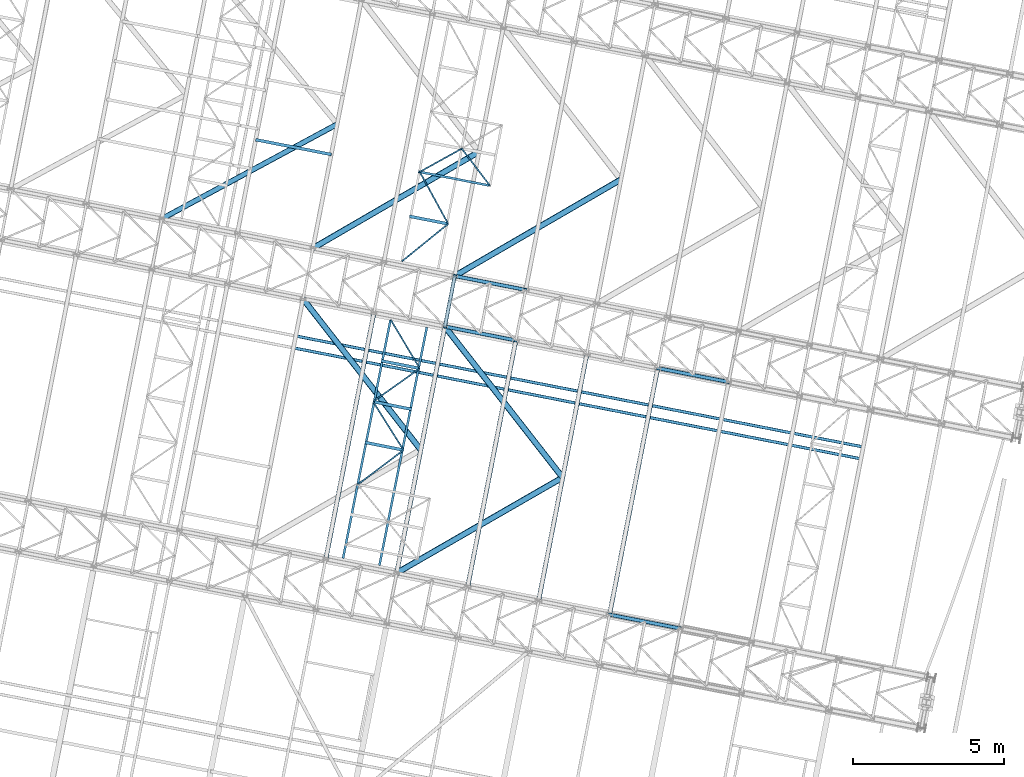
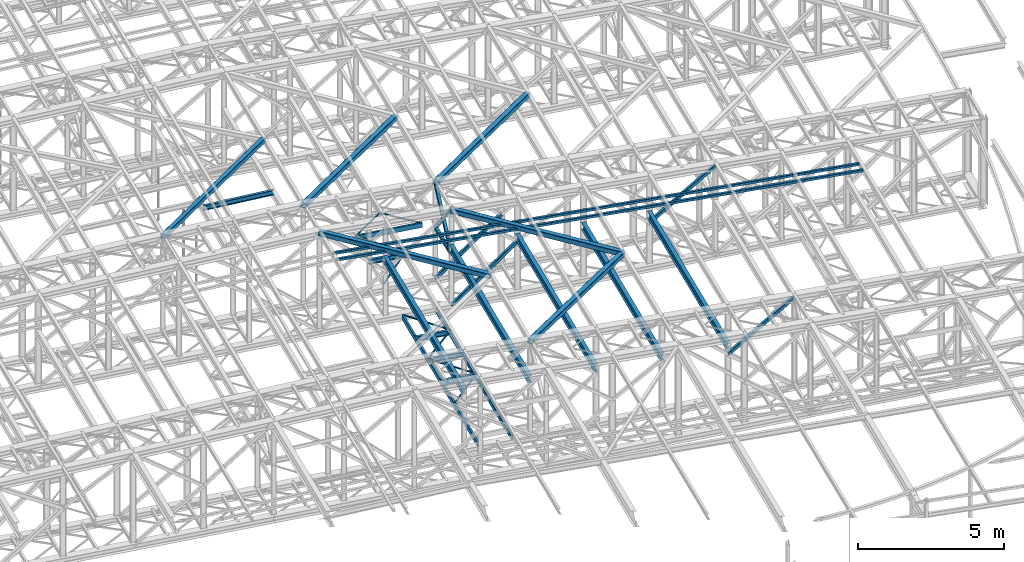
# One storey, part 60 of 215: 30 beams, 6 members, 36 elements without a shape of their own.
"""IFC2X3 building model written with IfcOpenShell, lengths in millimetres."""

from ifc_helpers import new_model, si_unit, frame, origin_with_axes, origin_2d_with_axis, place, context, subcontext, project, spatial, hollow_rectangle, i_section, u_section, extrude, material, type_object, element, aggregate, save


model = new_model("IFC2X3")

# Units and contexts
model_context = context("Model", 3, precision=1e-05, world=origin_with_axes())
body_context = subcontext(model_context, "Body", "Model", "MODEL_VIEW")
ifc_project = project(units=[si_unit("LENGTHUNIT", "METRE", prefix="MILLI"), si_unit("AREAUNIT", "SQUARE_METRE"), si_unit("VOLUMEUNIT", "CUBIC_METRE"), si_unit("MASSUNIT", "GRAM", prefix="KILO"), si_unit("TIMEUNIT", "SECOND"), si_unit("PLANEANGLEUNIT", "RADIAN"), si_unit("SOLIDANGLEUNIT", "STERADIAN"), si_unit("THERMODYNAMICTEMPERATUREUNIT", "DEGREE_CELSIUS"), si_unit("LUMINOUSINTENSITYUNIT", "LUMEN")], contexts=[model_context])

# Site, building, storey
site_placement = place(None, origin_with_axes())
site = spatial("IfcSite", under=ifc_project, at=site_placement, CompositionType="ELEMENT")
building_placement = place(site_placement, origin_with_axes())
building = spatial("IfcBuilding", under=site, at=building_placement, Name="Undefined", CompositionType="ELEMENT")
storey_placement = place(building_placement, origin_with_axes())
storey = spatial("IfcBuildingStorey", under=building, at=storey_placement, Name="Undefined", CompositionType="ELEMENT", Elevation=0.0)

# Assembly, beam
assembly_1_placement = place(storey_placement, origin_with_axes())
assembly_1 = element("IfcElementAssembly", 1, at=assembly_1_placement, inside=storey, Name="Steel Assembly", AssemblyPlace="NOTDEFINED", PredefinedType="RIGID_FRAME")
ifc_material = material(Name="STEEL/S275JR")
beam_type_1 = type_object("IfcBeamType", PredefinedType="NOTDEFINED")
beam_1_placement = place(assembly_1_placement, frame((73803.5514468927, 26333.0860836415, 10796.0000008389), z_axis=(0.981422364268518, -0.191859461052493, -0.000300197000082615), x_axis=(0.191859470081235, 0.981422408415534, 0.0)))
beam_1 = element("IfcBeam", 2, at=beam_1_placement, type_object=beam_type_1, material=ifc_material, context=body_context, shape_type="SweptSolid", body=[
    extrude(hollow_rectangle(XDim=120.0, YDim=120.0, WallThickness=5.0, InnerFilletRadius=5.0, OuterFilletRadius=10.0, at=origin_2d_with_axis()), frame((1699.99999941724, 1.81898940354586e-12, 0.0), z_axis=(-1.0, 0.0, 0.0), x_axis=(-6.93889390390723e-18, -1.0, -3.46944695195361e-18)), (0.0, 0.0, 1.0), 1700.0),
])
aggregate(assembly_1, [beam_1])

assembly_2_placement = place(storey_placement, origin_with_axes())
assembly_2 = element("IfcElementAssembly", 3, at=assembly_2_placement, inside=storey, Name="Steel Assembly", AssemblyPlace="NOTDEFINED", PredefinedType="RIGID_FRAME")
beam_type_2 = type_object("IfcBeamType", PredefinedType="NOTDEFINED")
beam_2_placement = place(assembly_2_placement, frame((68930.1374258507, 26009.7768922294, 12727.9809499878), z_axis=(-0.0304080339975108, 0.00594450399951394, -0.999519891918418), x_axis=(0.980943076639626, -0.191809005929534, -0.0309836349886174)))
beam_2 = element("IfcBeam", 4, at=beam_2_placement, type_object=beam_type_2, material=ifc_material, context=body_context, shape_type="SweptSolid", body=[
    extrude(hollow_rectangle(XDim=100.0, YDim=100.0, WallThickness=5.0, InnerFilletRadius=5.0, OuterFilletRadius=10.0, at=origin_2d_with_axis()), frame((19054.6230953848, 6.46745726067925e-12, -1.32218008037815e-13), z_axis=(-1.0, 0.0, 0.0), x_axis=(-6.93889390390723e-18, -1.0, -3.46944695195361e-18)), (0.0, 0.0, 1.0), 19054.6),
])
aggregate(assembly_2, [beam_2])

assembly_3_placement = place(storey_placement, origin_with_axes())
assembly_3 = element("IfcElementAssembly", 5, at=assembly_3_placement, inside=storey, Name="Steel Assembly", AssemblyPlace="NOTDEFINED", PredefinedType="RIGID_FRAME")
beam_3_placement = place(assembly_3_placement, frame((68853.376958442, 25617.2111899104, 12727.9809498765), z_axis=(-0.0304080339975108, 0.00594450399951394, -0.999519891918418), x_axis=(0.980943076639626, -0.191809005929534, -0.0309836349886174)))
beam_3 = element("IfcBeam", 6, at=beam_3_placement, type_object=beam_type_2, material=ifc_material, context=body_context, shape_type="SweptSolid", body=[
    extrude(hollow_rectangle(XDim=100.0, YDim=100.0, WallThickness=5.0, InnerFilletRadius=5.0, OuterFilletRadius=10.0, at=origin_2d_with_axis()), frame((19054.6230953848, 6.46745726067925e-12, -1.32218008037815e-13), z_axis=(-1.0, 0.0, 0.0), x_axis=(-6.93889390390723e-18, -1.0, -3.46944695195361e-18)), (0.0, 0.0, 1.0), 19054.6),
])
aggregate(assembly_3, [beam_3])

assembly_4_placement = place(storey_placement, origin_with_axes())
assembly_4 = element("IfcElementAssembly", 7, at=assembly_4_placement, inside=storey, Name="Steel Assembly", AssemblyPlace="NOTDEFINED", PredefinedType="RIGID_FRAME")
beam_type_3 = type_object("IfcBeamType", PredefinedType="NOTDEFINED")
beam_4_placement = place(assembly_4_placement, frame((73910.5829988377, 29724.9162021048, 8745.0), z_axis=(0.0, 0.0, -1.0), x_axis=(-0.776901735888944, -0.629621864909999, 0.0)))
beam_4 = element("IfcBeam", 8, at=beam_4_placement, type_object=beam_type_3, material=ifc_material, context=body_context, shape_type="SweptSolid", body=[
    extrude(hollow_rectangle(XDim=50.0, YDim=50.0, WallThickness=3.0, InnerFilletRadius=3.0, OuterFilletRadius=6.0, at=origin_2d_with_axis()), frame((1967.92286163102, 0.0, 0.0), z_axis=(-1.0, 0.0, 0.0), x_axis=(-6.93889390390723e-18, -1.0, -3.46944695195361e-18)), (0.0, 0.0, 1.0), 1967.9),
])
aggregate(assembly_4, [beam_4])

assembly_5_placement = place(storey_placement, origin_with_axes())
assembly_5 = element("IfcElementAssembly", 9, at=assembly_5_placement, inside=storey, Name="Steel Assembly", AssemblyPlace="NOTDEFINED", PredefinedType="RIGID_FRAME")
beam_5_placement = place(assembly_5_placement, frame((72972.494718833, 31442.4142075838, 8745.0), z_axis=(0.0, 0.0, -1.0), x_axis=(0.479352670880574, -0.877622365781354, 0.0)))
beam_5 = element("IfcBeam", 10, at=beam_5_placement, type_object=beam_type_3, material=ifc_material, context=body_context, shape_type="SweptSolid", body=[
    extrude(hollow_rectangle(XDim=50.0, YDim=50.0, WallThickness=3.0, InnerFilletRadius=3.0, OuterFilletRadius=6.0, at=origin_2d_with_axis()), frame((1956.98978542684, 0.0, 0.0), z_axis=(-1.0, 0.0, 0.0), x_axis=(-6.93889390390723e-18, -1.0, -3.46944695195361e-18)), (0.0, 0.0, 1.0), 1957.0),
])
aggregate(assembly_5, [beam_5])

assembly_6_placement = place(storey_placement, origin_with_axes())
assembly_6 = element("IfcElementAssembly", 11, at=assembly_6_placement, inside=storey, Name="Steel Assembly", AssemblyPlace="NOTDEFINED", PredefinedType="RIGID_FRAME")
beam_6_placement = place(assembly_6_placement, frame((72972.494718833, 31442.4142075838, 8745.0), z_axis=(0.0, 0.0, -1.0), x_axis=(0.874632709458512, 0.484786162699868, 0.0)))
beam_6 = element("IfcBeam", 12, at=beam_6_placement, type_object=beam_type_3, material=ifc_material, context=body_context, shape_type="SweptSolid", body=[
    extrude(hollow_rectangle(XDim=50.0, YDim=50.0, WallThickness=3.0, InnerFilletRadius=3.0, OuterFilletRadius=6.0, at=origin_2d_with_axis()), frame((1585.49676732963, -5.45696821063757e-12, -1.81898940354586e-12), z_axis=(-1.0, 0.0, 0.0), x_axis=(-6.93889390390723e-18, -1.0, -3.46944695195361e-18)), (0.0, 0.0, 1.0), 1585.5),
])
aggregate(assembly_6, [beam_6])

assembly_7_placement = place(storey_placement, origin_with_axes())
assembly_7 = element("IfcElementAssembly", 13, at=assembly_7_placement, inside=storey, Name="Steel Assembly", AssemblyPlace="NOTDEFINED", PredefinedType="RIGID_FRAME")
beam_7_placement = place(assembly_7_placement, frame((74359.2226940093, 32211.0444873669, 8745.0), z_axis=(0.0, 0.0, -1.0), x_axis=(0.606331787679529, -0.795211772579699, 0.0)))
beam_7 = element("IfcBeam", 14, at=beam_7_placement, type_object=beam_type_3, material=ifc_material, context=body_context, shape_type="SweptSolid", body=[
    extrude(hollow_rectangle(XDim=50.0, YDim=50.0, WallThickness=3.0, InnerFilletRadius=3.0, OuterFilletRadius=6.0, at=origin_2d_with_axis()), frame((1538.169383869, 0.0, 1.81898940354586e-12), z_axis=(-1.0, 0.0, 0.0), x_axis=(-6.93889390390723e-18, -1.0, -3.46944695195361e-18)), (0.0, 0.0, 1.0), 1538.2),
])
aggregate(assembly_7, [beam_7])

assembly_8_placement = place(storey_placement, origin_with_axes())
assembly_8 = element("IfcElementAssembly", 15, at=assembly_8_placement, inside=storey, Name="Steel Assembly", AssemblyPlace="NOTDEFINED", PredefinedType="RIGID_FRAME")
beam_8_placement = place(assembly_8_placement, frame((72436.2666917399, 22250.5172943073, 8745.0), z_axis=(0.0, 0.0, -1.0), x_axis=(-0.799182100298458, -0.601088987224475, 0.0)))
beam_8 = element("IfcBeam", 16, at=beam_8_placement, type_object=beam_type_3, material=ifc_material, context=body_context, shape_type="SweptSolid", body=[
    extrude(hollow_rectangle(XDim=50.0, YDim=50.0, WallThickness=3.0, InnerFilletRadius=3.0, OuterFilletRadius=6.0, at=origin_2d_with_axis()), frame((1894.42434231418, -2.10323352324758e-13, 0.0), z_axis=(-1.0, 0.0, 0.0), x_axis=(-6.93889390390723e-18, -1.0, -3.46944695195361e-18)), (0.0, 0.0, 1.0), 1894.4),
])
aggregate(assembly_8, [beam_8])

assembly_9_placement = place(storey_placement, origin_with_axes())
assembly_9 = element("IfcElementAssembly", 17, at=assembly_9_placement, inside=storey, Name="Steel Assembly", AssemblyPlace="NOTDEFINED", PredefinedType="RIGID_FRAME")
beam_9_placement = place(assembly_9_placement, frame((71429.7896565875, 23852.7578601774, 8745.0), z_axis=(0.0, 0.0, -1.0), x_axis=(0.531926949772059, -0.846790245637131, 0.0)))
beam_9 = element("IfcBeam", 18, at=beam_9_placement, type_object=beam_type_3, material=ifc_material, context=body_context, shape_type="SweptSolid", body=[
    extrude(hollow_rectangle(XDim=50.0, YDim=50.0, WallThickness=3.0, InnerFilletRadius=3.0, OuterFilletRadius=6.0, at=origin_2d_with_axis()), frame((1892.13394173326, 0.0, 0.0), z_axis=(-1.0, 0.0, 0.0), x_axis=(-6.93889390390723e-18, -1.0, -3.46944695195361e-18)), (0.0, 0.0, 1.0), 1892.1),
])
aggregate(assembly_9, [beam_9])

assembly_10_placement = place(storey_placement, origin_with_axes())
assembly_10 = element("IfcElementAssembly", 19, at=assembly_10_placement, inside=storey, Name="Steel Assembly", AssemblyPlace="NOTDEFINED", PredefinedType="RIGID_FRAME")
beam_10_placement = place(assembly_10_placement, frame((72973.2361306411, 24947.2721146437, 8745.0), z_axis=(0.0, 0.0, -1.0), x_axis=(-0.815715337122236, -0.57845353208668, 0.0)))
beam_10 = element("IfcBeam", 20, at=beam_10_placement, type_object=beam_type_3, material=ifc_material, context=body_context, shape_type="SweptSolid", body=[
    extrude(hollow_rectangle(XDim=50.0, YDim=50.0, WallThickness=3.0, InnerFilletRadius=3.0, OuterFilletRadius=6.0, at=origin_2d_with_axis()), frame((1892.13859743143, 0.0, 0.0), z_axis=(-1.0, 0.0, 0.0), x_axis=(-6.93889390390723e-18, -1.0, -3.46944695195361e-18)), (0.0, 0.0, 1.0), 1892.1),
])
aggregate(assembly_10, [beam_10])

assembly_11_placement = place(storey_placement, origin_with_axes())
assembly_11 = element("IfcElementAssembly", 21, at=assembly_11_placement, inside=storey, Name="Steel Assembly", AssemblyPlace="NOTDEFINED", PredefinedType="RIGID_FRAME")
beam_11_placement = place(assembly_11_placement, frame((72011.5958000029, 26561.0332888829, 8745.0), z_axis=(0.0, 0.0, -1.0), x_axis=(0.511903665923393, -0.859042860871442, 0.0)))
beam_11 = element("IfcBeam", 22, at=beam_11_placement, type_object=beam_type_3, material=ifc_material, context=body_context, shape_type="SweptSolid", body=[
    extrude(hollow_rectangle(XDim=50.0, YDim=50.0, WallThickness=3.0, InnerFilletRadius=3.0, OuterFilletRadius=6.0, at=origin_2d_with_axis()), frame((1878.55722617164, 1.44476343540883e-11, 0.0), z_axis=(-1.0, 0.0, 0.0), x_axis=(-6.93889390390723e-18, -1.0, -3.46944695195361e-18)), (0.0, 0.0, 1.0), 1878.6),
])
aggregate(assembly_11, [beam_11])

assembly_12_placement = place(storey_placement, origin_with_axes())
assembly_12 = element("IfcElementAssembly", 23, at=assembly_12_placement, inside=storey, Name="Steel Assembly", AssemblyPlace="NOTDEFINED", PredefinedType="RIGID_FRAME")
beam_type_4 = type_object("IfcBeamType", Name="UPN200", PredefinedType="NOTDEFINED")
beam_12_placement = place(assembly_12_placement, frame((72923.7516788256, 31451.4251382555, 8670.00000003361), z_axis=(0.0, 0.0, -1.0), x_axis=(0.981375096584427, -0.192101326918653, 0.0)))
beam_12 = element("IfcBeam", 24, at=beam_12_placement, type_object=beam_type_4, material=ifc_material, ObjectType="UPN200", context=body_context, shape_type="SweptSolid", body=[
    extrude(u_section(Depth=200.0, FlangeWidth=75.0, WebThickness=8.5, FlangeThickness=11.5, FilletRadius=11.5, EdgeRadius=6.0, FlangeSlope=0.0798299857122373, at=origin_2d_with_axis()), frame((2450.55492376749, 6.80165624868804e-14, 0.0), z_axis=(-1.0, 0.0, 0.0), x_axis=(-6.93889390390723e-18, -1.0, -3.46944695195361e-18)), (0.0, 0.0, 1.0), 2450.6),
])
aggregate(assembly_12, [beam_12])

assembly_13_placement = place(storey_placement, origin_with_axes())
assembly_13 = element("IfcElementAssembly", 25, at=assembly_13_placement, inside=storey, Name="Steel Assembly", AssemblyPlace="NOTDEFINED", PredefinedType="RIGID_FRAME")
beam_13_placement = place(assembly_13_placement, frame((72003.5163613566, 26542.1939828094, 8670.0000000337), z_axis=(0.0, 0.0, -1.0), x_axis=(-0.195275706966075, -0.980748386829619, 0.0)))
beam_13 = element("IfcBeam", 26, at=beam_13_placement, type_object=beam_type_4, material=ifc_material, ObjectType="UPN200", context=body_context, shape_type="SweptSolid", body=[
    extrude(u_section(Depth=200.0, FlangeWidth=75.0, WebThickness=8.5, FlangeThickness=11.5, FilletRadius=11.5, EdgeRadius=6.0, FlangeSlope=0.0798299857122373, at=origin_2d_with_axis()), frame((8020.04435865904, 2.22600947637459e-13, 0.0), z_axis=(-1.0, 0.0, 0.0), x_axis=(-6.93889390390723e-18, -1.0, -3.46944695195361e-18)), (0.0, 0.0, 1.0), 8020.0),
])
aggregate(assembly_13, [beam_13])

assembly_14_placement = place(storey_placement, origin_with_axes())
assembly_14 = element("IfcElementAssembly", 27, at=assembly_14_placement, inside=storey, Name="Steel Assembly", AssemblyPlace="NOTDEFINED", PredefinedType="RIGID_FRAME")
beam_14_placement = place(assembly_14_placement, frame((71639.6576296686, 18441.7832191884, 8670.00000000005), z_axis=(0.0, 0.0, -1.0), x_axis=(0.195280701088085, 0.980747392442389, 0.0)))
beam_14 = element("IfcBeam", 28, at=beam_14_placement, type_object=beam_type_4, material=ifc_material, ObjectType="UPN200", context=body_context, shape_type="SweptSolid", body=[
    extrude(u_section(Depth=200.0, FlangeWidth=75.0, WebThickness=8.5, FlangeThickness=11.5, FilletRadius=11.5, EdgeRadius=6.0, FlangeSlope=0.0798299857122373, at=origin_2d_with_axis()), frame((8020.04452082332, 0.0, 0.0), z_axis=(-1.0, 0.0, 0.0), x_axis=(-6.93889390390723e-18, -1.0, -3.46944695195361e-18)), (0.0, 0.0, 1.0), 8020.0),
])
aggregate(assembly_14, [beam_14])

# Assembly, member
assembly_15_placement = place(storey_placement, origin_with_axes())
assembly_15 = element("IfcElementAssembly", 29, at=assembly_15_placement, inside=storey, Name="Steel Assembly", AssemblyPlace="NOTDEFINED", PredefinedType="RIGID_FRAME")
member_type = type_object("IfcMemberType", PredefinedType="NOTDEFINED")
member_1_placement = place(assembly_15_placement, frame((74129.7125455571, 28001.5041774558, 10796.0000008371), z_axis=(0.981465144014204, -0.191640629002775, 0.000200999000003501), x_axis=(-0.128461058963395, -0.657119307812757, 0.742759699788354)))
member_1 = element("IfcMember", 30, at=member_1_placement, type_object=member_type, material=ifc_material, context=body_context, shape_type="SweptSolid", body=[
    extrude(hollow_rectangle(XDim=120.0, YDim=120.0, WallThickness=5.0, InnerFilletRadius=5.0, OuterFilletRadius=10.0, at=origin_2d_with_axis()), frame((2538.98807297308, -7.4168997650766e-12, -1.4616192556948e-11), z_axis=(-1.0, 0.0, 0.0), x_axis=(-6.93889390390723e-18, -1.0, -3.46944695195361e-18)), (0.0, 0.0, 1.0), 2539.0),
])
aggregate(assembly_15, [member_1])

assembly_16_placement = place(storey_placement, origin_with_axes())
assembly_16 = element("IfcElementAssembly", 31, at=assembly_16_placement, inside=storey, Name="Steel Assembly", AssemblyPlace="NOTDEFINED", PredefinedType="RIGID_FRAME")
member_2_placement = place(assembly_16_placement, frame((73803.5514468927, 26333.0860836415, 10796.0000008389), z_axis=(0.981465144014204, -0.191640629002775, -0.000200999000003501), x_axis=(0.128461059990898, 0.657119311953447, 0.742759695947379)))
member_2 = element("IfcMember", 32, at=member_2_placement, type_object=member_type, material=ifc_material, context=body_context, shape_type="SweptSolid", body=[
    extrude(hollow_rectangle(XDim=120.0, YDim=120.0, WallThickness=5.0, InnerFilletRadius=5.0, OuterFilletRadius=10.0, at=origin_2d_with_axis()), frame((2538.98807297308, -7.4168997650766e-12, -1.4616192556948e-11), z_axis=(-1.0, 0.0, 0.0), x_axis=(-6.93889390390723e-18, -1.0, -3.46944695195361e-18)), (0.0, 0.0, 1.0), 2539.0),
])
aggregate(assembly_16, [member_2])

assembly_17_placement = place(storey_placement, origin_with_axes())
assembly_17 = element("IfcElementAssembly", 33, at=assembly_17_placement, inside=storey, Name="Steel Assembly", AssemblyPlace="NOTDEFINED", PredefinedType="RIGID_FRAME")
member_3_placement = place(assembly_17_placement, frame((79243.2624942641, 16812.5620284464, 10489.6726253048), z_axis=(0.597857237183729, -0.116875832035918, -0.793036420243705), x_axis=(0.778303714010845, -0.15215154400212, 0.609174225008491)))
member_3 = element("IfcMember", 34, at=member_3_placement, type_object=member_type, material=ifc_material, context=body_context, shape_type="SweptSolid", body=[
    extrude(hollow_rectangle(XDim=120.0, YDim=120.0, WallThickness=5.0, InnerFilletRadius=5.0, OuterFilletRadius=10.0, at=origin_2d_with_axis()), frame((3005.68349365877, -3.45147056449385e-14, 7.44280656515321e-12), z_axis=(-1.0, 0.0, 0.0), x_axis=(-6.93889390390723e-18, -1.0, -3.46944695195361e-18)), (0.0, 0.0, 1.0), 3005.7),
])
aggregate(assembly_17, [member_3])

assembly_18_placement = place(storey_placement, origin_with_axes())
assembly_18 = element("IfcElementAssembly", 35, at=assembly_18_placement, inside=storey, Name="Steel Assembly", AssemblyPlace="NOTDEFINED", PredefinedType="RIGID_FRAME")
member_4_placement = place(assembly_18_placement, frame((80835.6953486146, 24958.3638822808, 10489.6726246075), z_axis=(0.597857237183729, -0.116875832035918, -0.793036420243705), x_axis=(0.778303714010845, -0.15215154400212, 0.609174225008491)))
member_4 = element("IfcMember", 36, at=member_4_placement, type_object=member_type, material=ifc_material, context=body_context, shape_type="SweptSolid", body=[
    extrude(hollow_rectangle(XDim=120.0, YDim=120.0, WallThickness=5.0, InnerFilletRadius=5.0, OuterFilletRadius=10.0, at=origin_2d_with_axis()), frame((3005.68349365877, -3.45147056449385e-14, 7.44280656515321e-12), z_axis=(-1.0, 0.0, 0.0), x_axis=(-6.93889390390723e-18, -1.0, -3.46944695195361e-18)), (0.0, 0.0, 1.0), 3005.7),
])
aggregate(assembly_18, [member_4])

assembly_19_placement = place(storey_placement, origin_with_axes())
assembly_19 = element("IfcElementAssembly", 37, at=assembly_19_placement, inside=storey, Name="Steel Assembly", AssemblyPlace="NOTDEFINED", PredefinedType="RIGID_FRAME")
member_5_placement = place(assembly_19_placement, frame((74134.4260198793, 28000.5828276486, 8654.99756456188), z_axis=(0.655814943165359, -0.128217045032329, -0.743953728187577), x_axis=(0.730132860802437, -0.142734564961378, 0.668231134819185)))
member_5 = element("IfcMember", 38, at=member_5_placement, type_object=member_type, material=ifc_material, context=body_context, shape_type="SweptSolid", body=[
    extrude(hollow_rectangle(XDim=120.0, YDim=120.0, WallThickness=5.0, InnerFilletRadius=5.0, OuterFilletRadius=10.0, at=origin_2d_with_axis()), frame((3203.9848555289, -6.00376509824008e-14, -1.77856887857925e-13), z_axis=(-1.0, 0.0, 0.0), x_axis=(-6.93889390390723e-18, -1.0, -3.46944695195361e-18)), (0.0, 0.0, 1.0), 3204.0),
])
aggregate(assembly_19, [member_5])

assembly_20_placement = place(storey_placement, origin_with_axes())
assembly_20 = element("IfcElementAssembly", 39, at=assembly_20_placement, inside=storey, Name="Steel Assembly", AssemblyPlace="NOTDEFINED", PredefinedType="RIGID_FRAME")
member_6_placement = place(assembly_20_placement, frame((73808.2649528043, 26332.1647269562, 8654.99756456188), z_axis=(0.655814943165359, -0.128217045032329, -0.743953728187577), x_axis=(0.730132860802437, -0.142734564961378, 0.668231134819185)))
member_6 = element("IfcMember", 40, at=member_6_placement, type_object=member_type, material=ifc_material, context=body_context, shape_type="SweptSolid", body=[
    extrude(hollow_rectangle(XDim=120.0, YDim=120.0, WallThickness=5.0, InnerFilletRadius=5.0, OuterFilletRadius=10.0, at=origin_2d_with_axis()), frame((3203.9848555289, -6.00376509824008e-14, -1.77856887857925e-13), z_axis=(-1.0, 0.0, 0.0), x_axis=(-6.93889390390723e-18, -1.0, -3.46944695195361e-18)), (0.0, 0.0, 1.0), 3204.0),
])
aggregate(assembly_20, [member_6])

# Assembly, beam
assembly_21_placement = place(storey_placement, origin_with_axes())
assembly_21 = element("IfcElementAssembly", 41, at=assembly_21_placement, inside=storey, Name="Steel Assembly", AssemblyPlace="NOTDEFINED", PredefinedType="RIGID_FRAME")
beam_type_5 = type_object("IfcBeamType", PredefinedType="NOTDEFINED")
beam_15_placement = place(assembly_21_placement, frame((73003.2917783053, 22260.9758140549, 12638.8209988115), z_axis=(0.0303361180133672, -0.00559522800246258, 0.999524093440213), x_axis=(-0.614883443932453, 0.788280351913406, 0.0230745999974651)))
beam_15 = element("IfcBeam", 42, at=beam_15_placement, type_object=beam_type_5, material=ifc_material, context=body_context, shape_type="SweptSolid", body=[
    extrude(hollow_rectangle(XDim=200.0, YDim=200.0, WallThickness=10.0, InnerFilletRadius=15.0, OuterFilletRadius=25.0, at=origin_2d_with_axis()), frame((6329.45024744155, -2.78613590581951e-13, 0.0), z_axis=(-1.0, 0.0, 0.0), x_axis=(-6.93889390390723e-18, -1.0, -3.46944695195361e-18)), (0.0, 0.0, 1.0), 6329.5),
])
aggregate(assembly_21, [beam_15])

assembly_22_placement = place(storey_placement, origin_with_axes())
assembly_22 = element("IfcElementAssembly", 43, at=assembly_22_placement, inside=storey, Name="Steel Assembly", AssemblyPlace="NOTDEFINED", PredefinedType="RIGID_FRAME")
beam_16_placement = place(assembly_22_placement, frame((77691.3875130413, 21344.4941957404, 12490.7460998416), z_axis=(0.0303361180133672, -0.00559522800246258, 0.999524093440213), x_axis=(-0.614883443932453, 0.788280351913406, 0.0230745999974651)))
beam_16 = element("IfcBeam", 44, at=beam_16_placement, type_object=beam_type_5, material=ifc_material, context=body_context, shape_type="SweptSolid", body=[
    extrude(hollow_rectangle(XDim=200.0, YDim=200.0, WallThickness=10.0, InnerFilletRadius=15.0, OuterFilletRadius=25.0, at=origin_2d_with_axis()), frame((6329.45024744155, -2.78613590581951e-13, 0.0), z_axis=(-1.0, 0.0, 0.0), x_axis=(-6.93889390390723e-18, -1.0, -3.46944695195361e-18)), (0.0, 0.0, 1.0), 6329.5),
])
aggregate(assembly_22, [beam_16])

assembly_23_placement = place(storey_placement, origin_with_axes())
assembly_23 = element("IfcElementAssembly", 45, at=assembly_23_placement, inside=storey, Name="Steel Assembly", AssemblyPlace="NOTDEFINED", PredefinedType="RIGID_FRAME")
beam_17_placement = place(assembly_23_placement, frame((77691.3259601863, 21344.5062289332, 12488.7228489195), z_axis=(0.0304080349965938, -0.00594450399933318, 0.999519891888024), x_axis=(-0.866468094253426, -0.498684012145856, 0.0233943940068423)))
beam_17 = element("IfcBeam", 46, at=beam_17_placement, type_object=beam_type_5, material=ifc_material, context=body_context, shape_type="SweptSolid", body=[
    extrude(hollow_rectangle(XDim=200.0, YDim=200.0, WallThickness=10.0, InnerFilletRadius=15.0, OuterFilletRadius=25.0, at=origin_2d_with_axis()), frame((6329.49911177436, 3.28490541050796e-12, -2.19598614007387e-14), z_axis=(-1.0, 0.0, 0.0), x_axis=(-6.93889390390723e-18, -1.0, -3.46944695195361e-18)), (0.0, 0.0, 1.0), 6329.5),
])
aggregate(assembly_23, [beam_17])

assembly_24_placement = place(storey_placement, origin_with_axes())
assembly_24 = element("IfcElementAssembly", 47, at=assembly_24_placement, inside=storey, Name="Steel Assembly", AssemblyPlace="NOTDEFINED", PredefinedType="RIGID_FRAME")
beam_18_placement = place(assembly_24_placement, frame((74927.7617895528, 32105.5818899006, 12636.7977459321), z_axis=(0.0304080349965938, -0.00594450399933318, 0.999519891888024), x_axis=(-0.864628555736928, -0.501870164847301, 0.0233194819929049)))
beam_18 = element("IfcBeam", 48, at=beam_18_placement, type_object=beam_type_5, material=ifc_material, context=body_context, shape_type="SweptSolid", body=[
    extrude(hollow_rectangle(XDim=200.0, YDim=200.0, WallThickness=10.0, InnerFilletRadius=15.0, OuterFilletRadius=25.0, at=origin_2d_with_axis()), frame((6349.83661532856, 5.61049270900543e-12, 1.81898940354586e-12), z_axis=(-1.0, 0.0, 0.0), x_axis=(-6.93889390390723e-18, -1.0, -3.46944695195361e-18)), (0.0, 0.0, 1.0), 6349.8),
])
aggregate(assembly_24, [beam_18])

assembly_25_placement = place(storey_placement, origin_with_axes())
assembly_25 = element("IfcElementAssembly", 49, at=assembly_25_placement, inside=storey, Name="Steel Assembly", AssemblyPlace="NOTDEFINED", PredefinedType="RIGID_FRAME")
beam_19_placement = place(assembly_25_placement, frame((79615.8575243625, 31189.1002715224, 12488.722846983), z_axis=(0.0304080349965938, -0.00594450399933318, 0.999519891888024), x_axis=(-0.864628555736928, -0.501870164847301, 0.0233194819929049)))
beam_19 = element("IfcBeam", 50, at=beam_19_placement, type_object=beam_type_5, material=ifc_material, context=body_context, shape_type="SweptSolid", body=[
    extrude(hollow_rectangle(XDim=200.0, YDim=200.0, WallThickness=10.0, InnerFilletRadius=15.0, OuterFilletRadius=25.0, at=origin_2d_with_axis()), frame((6349.83661532856, 5.61049270900543e-12, 1.81898940354586e-12), z_axis=(-1.0, 0.0, 0.0), x_axis=(-6.93889390390723e-18, -1.0, -3.46944695195361e-18)), (0.0, 0.0, 1.0), 6349.8),
])
aggregate(assembly_25, [beam_19])

assembly_26_placement = place(storey_placement, origin_with_axes())
assembly_26 = element("IfcElementAssembly", 51, at=assembly_26_placement, inside=storey, Name="Steel Assembly", AssemblyPlace="NOTDEFINED", PredefinedType="RIGID_FRAME")
beam_type_6 = type_object("IfcBeamType", PredefinedType="NOTDEFINED")
beam_20_placement = place(assembly_26_placement, frame((70247.7684552626, 33020.2282585387, 12784.8705300003), z_axis=(-0.0304080349967745, 0.00594450299936818, 0.999519891893966), x_axis=(-0.879777562863468, -0.474782314926319, -0.0239414559962845)))
beam_20 = element("IfcBeam", 52, at=beam_20_placement, type_object=beam_type_6, material=ifc_material, context=body_context, shape_type="SweptSolid", body=[
    extrude(hollow_rectangle(XDim=180.0, YDim=180.0, WallThickness=8.0, InnerFilletRadius=12.0, OuterFilletRadius=20.0, at=origin_2d_with_axis()), frame((6586.3148658864, 6.71601352153469e-13, 0.0), z_axis=(-1.0, 0.0, 0.0), x_axis=(-6.93889390390723e-18, -1.0, -3.46944695195361e-18)), (0.0, 0.0, 1.0), 6586.3),
])
aggregate(assembly_26, [beam_20])

assembly_27_placement = place(storey_placement, origin_with_axes())
assembly_27 = element("IfcElementAssembly", 53, at=assembly_27_placement, inside=storey, Name="Steel Assembly", AssemblyPlace="NOTDEFINED", PredefinedType="RIGID_FRAME")
beam_type_7 = type_object("IfcBeamType", Name="IPE300", PredefinedType="NOTDEFINED")
beam_21_placement = place(assembly_27_placement, frame((79243.2669873738, 16812.5616994376, 10827.66000008), z_axis=(0.0, 0.0, 1.0), x_axis=(0.191859470081235, 0.981422408415534, 0.0)))
beam_21 = element("IfcBeam", 54, at=beam_21_placement, type_object=beam_type_7, material=ifc_material, Name="SUPPORT", ObjectType="IPE300", context=body_context, shape_type="SweptSolid", body=[
    extrude(i_section(OverallWidth=150.0, OverallDepth=300.0, WebThickness=7.099999905, FlangeThickness=10.69999981, FilletRadius=15.0, at=origin_2d_with_axis()), frame((8299.99526300685, 1.47838788079098e-11, -1.71639879146031e-21), z_axis=(-1.0, 0.0, 0.0), x_axis=(-6.93889390390723e-18, -1.0, -3.46944695195361e-18)), (0.0, 0.0, 1.0), 8300.0),
])
aggregate(assembly_27, [beam_21])

assembly_28_placement = place(storey_placement, origin_with_axes())
assembly_28 = element("IfcElementAssembly", 55, at=assembly_28_placement, inside=storey, Name="Steel Assembly", AssemblyPlace="NOTDEFINED", PredefinedType="RIGID_FRAME")
beam_22_placement = place(assembly_28_placement, frame((76899.2191085495, 17270.8024461081, 10901.7000000974), z_axis=(0.0, 0.0, 1.0), x_axis=(0.191859470081235, 0.981422408415534, 0.0)))
beam_22 = element("IfcBeam", 56, at=beam_22_placement, type_object=beam_type_7, material=ifc_material, Name="SUPPORT", ObjectType="IPE300", context=body_context, shape_type="SweptSolid", body=[
    extrude(i_section(OverallWidth=150.0, OverallDepth=300.0, WebThickness=7.099999905, FlangeThickness=10.69999981, FilletRadius=15.0, at=origin_2d_with_axis()), frame((8299.99526300685, 1.47838788079098e-11, -1.71639879146031e-21), z_axis=(-1.0, 0.0, 0.0), x_axis=(-6.93889390390723e-18, -1.0, -3.46944695195361e-18)), (0.0, 0.0, 1.0), 8300.0),
])
aggregate(assembly_28, [beam_22])

assembly_29_placement = place(storey_placement, origin_with_axes())
assembly_29 = element("IfcElementAssembly", 57, at=assembly_29_placement, inside=storey, Name="Steel Assembly", AssemblyPlace="NOTDEFINED", PredefinedType="RIGID_FRAME")
beam_23_placement = place(assembly_29_placement, frame((74555.1712275701, 17729.0431931012, 10975.7300001147), z_axis=(0.0, 0.0, 1.0), x_axis=(0.191859470081235, 0.981422408415534, 0.0)))
beam_23 = element("IfcBeam", 58, at=beam_23_placement, type_object=beam_type_7, material=ifc_material, Name="SUPPORT", ObjectType="IPE300", context=body_context, shape_type="SweptSolid", body=[
    extrude(i_section(OverallWidth=150.0, OverallDepth=300.0, WebThickness=7.099999905, FlangeThickness=10.69999981, FilletRadius=15.0, at=origin_2d_with_axis()), frame((8299.99526300685, 1.47838788079098e-11, -1.71639879146031e-21), z_axis=(-1.0, 0.0, 0.0), x_axis=(-6.93889390390723e-18, -1.0, -3.46944695195361e-18)), (0.0, 0.0, 1.0), 8300.0),
])
aggregate(assembly_29, [beam_23])

assembly_30_placement = place(storey_placement, origin_with_axes())
assembly_30 = element("IfcElementAssembly", 59, at=assembly_30_placement, inside=storey, Name="Steel Assembly", AssemblyPlace="NOTDEFINED", PredefinedType="RIGID_FRAME")
beam_24_placement = place(assembly_30_placement, frame((72211.1233480386, 18187.2839398113, 11049.7700001321), z_axis=(0.0, 0.0, 1.0), x_axis=(0.191859470081235, 0.981422408415534, 0.0)))
beam_24 = element("IfcBeam", 60, at=beam_24_placement, type_object=beam_type_7, material=ifc_material, Name="SUPPORT", ObjectType="IPE300", context=body_context, shape_type="SweptSolid", body=[
    extrude(i_section(OverallWidth=150.0, OverallDepth=300.0, WebThickness=7.099999905, FlangeThickness=10.69999981, FilletRadius=15.0, at=origin_2d_with_axis()), frame((8299.99526300685, 1.47838788079098e-11, -1.71639879146031e-21), z_axis=(-1.0, 0.0, 0.0), x_axis=(-6.93889390390723e-18, -1.0, -3.46944695195361e-18)), (0.0, 0.0, 1.0), 8300.0),
])
aggregate(assembly_30, [beam_24])

assembly_31_placement = place(storey_placement, origin_with_axes())
assembly_31 = element("IfcElementAssembly", 61, at=assembly_31_placement, inside=storey, Name="Steel Assembly", AssemblyPlace="NOTDEFINED", PredefinedType="RIGID_FRAME")
beam_25_placement = place(assembly_31_placement, frame((69867.075468313, 18645.5246864607, 11123.8100001495), z_axis=(0.0, 0.0, 1.0), x_axis=(0.191859470081235, 0.981422408415534, 0.0)))
beam_25 = element("IfcBeam", 62, at=beam_25_placement, type_object=beam_type_7, material=ifc_material, Name="SUPPORT", ObjectType="IPE300", context=body_context, shape_type="SweptSolid", body=[
    extrude(i_section(OverallWidth=150.0, OverallDepth=300.0, WebThickness=7.099999905, FlangeThickness=10.69999981, FilletRadius=15.0, at=origin_2d_with_axis()), frame((8299.99526300685, 1.47838788079098e-11, -1.71639879146031e-21), z_axis=(-1.0, 0.0, 0.0), x_axis=(-6.93889390390723e-18, -1.0, -3.46944695195361e-18)), (0.0, 0.0, 1.0), 8300.0),
])
aggregate(assembly_31, [beam_25])

assembly_32_placement = place(storey_placement, origin_with_axes())
assembly_32 = element("IfcElementAssembly", 63, at=assembly_32_placement, inside=storey, Name="Steel Assembly", AssemblyPlace="NOTDEFINED", PredefinedType="RIGID_FRAME")
beam_type_8 = type_object("IfcBeamType", Name="IPE200", PredefinedType="NOTDEFINED")
beam_26_placement = place(assembly_32_placement, frame((67554.5127992606, 32505.5385955178, 11169.0479375565), z_axis=(0.0303605499861654, -0.00593522099729565, -0.99952139054462), x_axis=(0.980952689077156, -0.191767651015084, 0.030935252002433)))
beam_26 = element("IfcBeam", 64, at=beam_26_placement, type_object=beam_type_8, material=ifc_material, ObjectType="IPE200", context=body_context, shape_type="SweptSolid", body=[
    extrude(i_section(OverallWidth=100.0, OverallDepth=200.0, WebThickness=5.599999905, FlangeThickness=8.5, FilletRadius=12.0, at=origin_2d_with_axis()), frame((2544.66727454958, 2.95700928513306e-14, 1.81016081542643e-12), z_axis=(-1.0, 0.0, 0.0), x_axis=(-6.93889390390723e-18, -1.0, -3.46944695195361e-18)), (0.0, 0.0, 1.0), 2544.7),
])
aggregate(assembly_32, [beam_26])

assembly_33_placement = place(storey_placement, origin_with_axes())
assembly_33 = element("IfcElementAssembly", 65, at=assembly_33_placement, inside=storey, Name="Steel Assembly", AssemblyPlace="NOTDEFINED", PredefinedType="RIGID_FRAME")
beam_27_placement = place(assembly_33_placement, frame((73910.5829988377, 29724.9162021048, 8670.00000000005), z_axis=(0.0, 0.0, -1.0), x_axis=(-0.981422412140383, 0.191859451027444, 0.0)))
beam_27 = element("IfcBeam", 66, at=beam_27_placement, type_object=beam_type_8, material=ifc_material, ObjectType="IPE200", context=body_context, shape_type="SweptSolid", body=[
    extrude(i_section(OverallWidth=100.0, OverallDepth=200.0, WebThickness=5.599999905, FlangeThickness=8.5, FilletRadius=12.0, at=origin_2d_with_axis()), frame((1300.00059478047, 0.0, -1.81898940354586e-12), z_axis=(-1.0, 0.0, 0.0), x_axis=(-6.93889390390723e-18, -1.0, -3.46944695195361e-18)), (0.0, 0.0, 1.0), 1300.0),
])
aggregate(assembly_33, [beam_27])

assembly_34_placement = place(storey_placement, origin_with_axes())
assembly_34 = element("IfcElementAssembly", 67, at=assembly_34_placement, inside=storey, Name="Steel Assembly", AssemblyPlace="NOTDEFINED", PredefinedType="RIGID_FRAME")
beam_28_placement = place(assembly_34_placement, frame((72436.2874903784, 22250.5131530003, 8670.00000000005), z_axis=(0.0, 0.0, -1.0), x_axis=(-0.980747361995622, 0.195280853999128, 0.0)))
beam_28 = element("IfcBeam", 68, at=beam_28_placement, type_object=beam_type_8, material=ifc_material, ObjectType="IPE200", context=body_context, shape_type="SweptSolid", body=[
    extrude(i_section(OverallWidth=100.0, OverallDepth=200.0, WebThickness=5.599999905, FlangeThickness=8.5, FilletRadius=12.0, at=origin_2d_with_axis()), frame((1300.00059478047, 0.0, -1.81898940354586e-12), z_axis=(-1.0, 0.0, 0.0), x_axis=(-6.93889390390723e-18, -1.0, -3.46944695195361e-18)), (0.0, 0.0, 1.0), 1300.0),
])
aggregate(assembly_34, [beam_28])

assembly_35_placement = place(storey_placement, origin_with_axes())
assembly_35 = element("IfcElementAssembly", 69, at=assembly_35_placement, inside=storey, Name="Steel Assembly", AssemblyPlace="NOTDEFINED", PredefinedType="RIGID_FRAME")
beam_29_placement = place(assembly_35_placement, frame((72704.7618105097, 23598.892633822, 8670.00000000005), z_axis=(0.0, 0.0, -1.0), x_axis=(-0.980747361995622, 0.195280853999128, 0.0)))
beam_29 = element("IfcBeam", 70, at=beam_29_placement, type_object=beam_type_8, material=ifc_material, ObjectType="IPE200", context=body_context, shape_type="SweptSolid", body=[
    extrude(i_section(OverallWidth=100.0, OverallDepth=200.0, WebThickness=5.599999905, FlangeThickness=8.5, FilletRadius=12.0, at=origin_2d_with_axis()), frame((1300.00059478047, 0.0, -1.81898940354586e-12), z_axis=(-1.0, 0.0, 0.0), x_axis=(-6.93889390390723e-18, -1.0, -3.46944695195361e-18)), (0.0, 0.0, 1.0), 1300.0),
])
aggregate(assembly_35, [beam_29])

assembly_36_placement = place(storey_placement, origin_with_axes())
assembly_36 = element("IfcElementAssembly", 71, at=assembly_36_placement, inside=storey, Name="Steel Assembly", AssemblyPlace="NOTDEFINED", PredefinedType="RIGID_FRAME")
beam_30_placement = place(assembly_36_placement, frame((72973.2361306411, 24947.2721146437, 8670.00000000005), z_axis=(0.0, 0.0, -1.0), x_axis=(-0.980747361995622, 0.195280853999128, 0.0)))
beam_30 = element("IfcBeam", 72, at=beam_30_placement, type_object=beam_type_8, material=ifc_material, ObjectType="IPE200", context=body_context, shape_type="SweptSolid", body=[
    extrude(i_section(OverallWidth=100.0, OverallDepth=200.0, WebThickness=5.599999905, FlangeThickness=8.5, FilletRadius=12.0, at=origin_2d_with_axis()), frame((1300.00059478047, 0.0, -1.81898940354586e-12), z_axis=(-1.0, 0.0, 0.0), x_axis=(-6.93889390390723e-18, -1.0, -3.46944695195361e-18)), (0.0, 0.0, 1.0), 1300.0),
])
aggregate(assembly_36, [beam_30])

save(model, "model.ifc")
